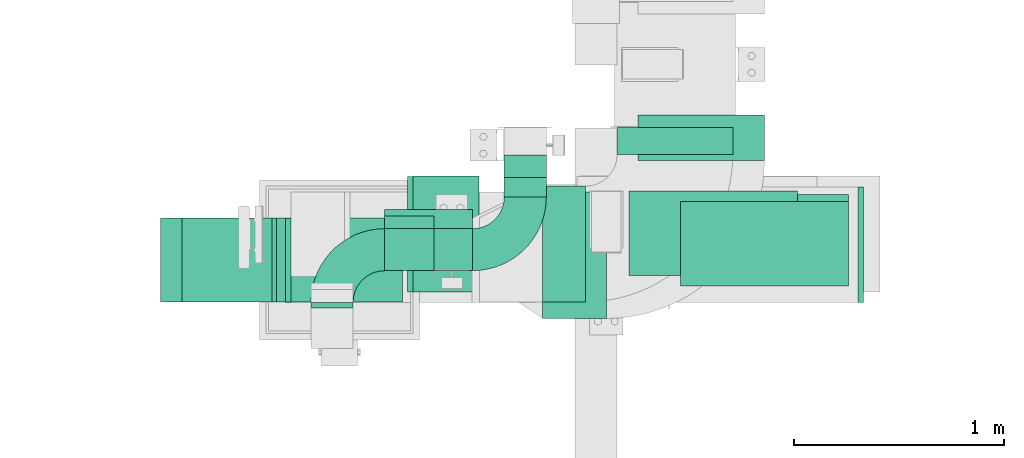
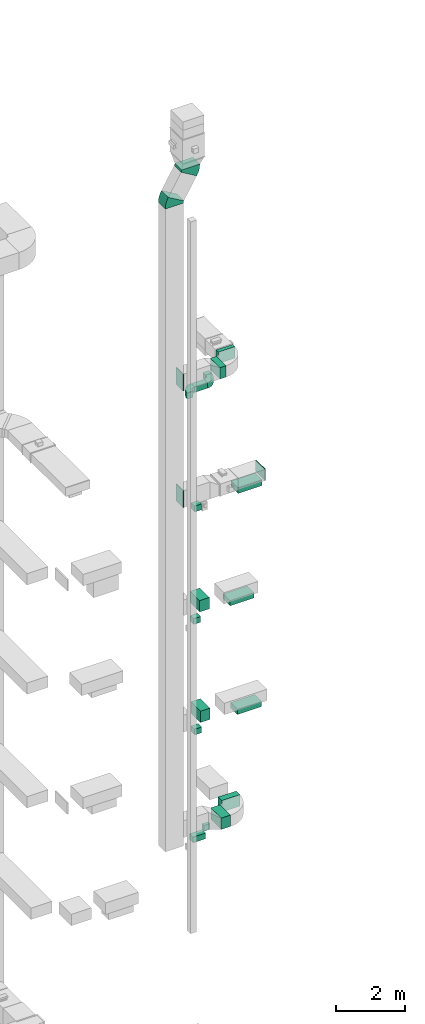
# One storey, part 10 of 25: 16 flow segments, 9 flow fittings.
"""IFC2X3 building model written with IfcOpenShell, lengths in millimetres."""

from ifc_helpers import new_model, entity, si_unit, converted_unit, derived_unit, direction, frame, frame_2d, origin, origin_2d_with_axis, place, context, subcontext, project, spatial, polyline, circle_curve, parameter, trimmed, segment, composite_curve, rectangle, outline, extrude, source, transform, mapped, material, type_object, type_shapes, element, save


model = new_model("IFC2X3")

# Units and contexts
model_context = context("Model", 3, precision=0.01, world=origin(), true_north=direction((6.12303176911189e-17, 1.0)))
body_context = subcontext(model_context, "Body", "Model", "MODEL_VIEW")
ifc_project = project(units=[si_unit("LENGTHUNIT", "METRE", prefix="MILLI"), si_unit("AREAUNIT", "SQUARE_METRE"), si_unit("VOLUMEUNIT", "CUBIC_METRE"), converted_unit("PLANEANGLEUNIT", "DEGREE", entity("IfcRatioMeasure", 0.0174532925199433), si_unit("PLANEANGLEUNIT", "RADIAN"), dimensions=[0, 0, 0, 0, 0, 0, 0]), si_unit("MASSUNIT", "GRAM", prefix="KILO"), derived_unit("MASSDENSITYUNIT", [(si_unit("MASSUNIT", "GRAM", prefix="KILO"), 1), (si_unit("LENGTHUNIT", "METRE"), -3)]), derived_unit("MOMENTOFINERTIAUNIT", [(si_unit("LENGTHUNIT", "METRE"), 4)]), si_unit("TIMEUNIT", "SECOND"), si_unit("FREQUENCYUNIT", "HERTZ"), si_unit("THERMODYNAMICTEMPERATUREUNIT", "DEGREE_CELSIUS"), derived_unit("THERMALTRANSMITTANCEUNIT", [(si_unit("MASSUNIT", "GRAM", prefix="KILO"), 1), (si_unit("THERMODYNAMICTEMPERATUREUNIT", "KELVIN"), -1), (si_unit("TIMEUNIT", "SECOND"), -3)]), derived_unit("VOLUMETRICFLOWRATEUNIT", [(si_unit("LENGTHUNIT", "METRE"), 3), (si_unit("TIMEUNIT", "SECOND"), -1)]), derived_unit("MASSFLOWRATEUNIT", [(si_unit("MASSUNIT", "GRAM", prefix="KILO"), 1), (si_unit("TIMEUNIT", "SECOND"), -1)]), derived_unit("ROTATIONALFREQUENCYUNIT", [(si_unit("TIMEUNIT", "SECOND"), -1)]), si_unit("ELECTRICCURRENTUNIT", "AMPERE"), si_unit("ELECTRICVOLTAGEUNIT", "VOLT"), si_unit("POWERUNIT", "WATT"), si_unit("FORCEUNIT", "NEWTON", prefix="KILO"), si_unit("ILLUMINANCEUNIT", "LUX"), si_unit("LUMINOUSFLUXUNIT", "LUMEN"), si_unit("LUMINOUSINTENSITYUNIT", "CANDELA"), derived_unit("USERDEFINED", [(si_unit("MASSUNIT", "GRAM", prefix="KILO"), -1), (si_unit("LENGTHUNIT", "METRE"), -2), (si_unit("TIMEUNIT", "SECOND"), 3), (si_unit("LUMINOUSFLUXUNIT", "LUMEN"), 1)]), derived_unit("LINEARVELOCITYUNIT", [(si_unit("LENGTHUNIT", "METRE"), 1), (si_unit("TIMEUNIT", "SECOND"), -1)]), si_unit("PRESSUREUNIT", "PASCAL"), derived_unit("USERDEFINED", [(si_unit("LENGTHUNIT", "METRE"), -2), (si_unit("MASSUNIT", "GRAM", prefix="KILO"), 1), (si_unit("TIMEUNIT", "SECOND"), -2)]), derived_unit("LINEARFORCEUNIT", [(si_unit("MASSUNIT", "GRAM", prefix="KILO"), 1), (si_unit("LENGTHUNIT", "METRE"), 1), (si_unit("TIMEUNIT", "SECOND"), -2), (si_unit("LENGTHUNIT", "METRE"), -1)]), derived_unit("PLANARFORCEUNIT", [(si_unit("MASSUNIT", "GRAM", prefix="KILO"), 1), (si_unit("LENGTHUNIT", "METRE"), 1), (si_unit("TIMEUNIT", "SECOND"), -2), (si_unit("LENGTHUNIT", "METRE"), -2)])], contexts=[model_context])

# Site, building, storey
site_placement = place(None, origin())
site = spatial("IfcSite", under=ifc_project, at=site_placement, CompositionType="ELEMENT")
building_placement = place(site_placement, origin())
building = spatial("IfcBuilding", under=site, at=building_placement, CompositionType="ELEMENT")
storey_placement = place(building_placement, origin())
storey = spatial("IfcBuildingStorey", under=building, at=storey_placement, CompositionType="ELEMENT", Elevation=0.0)

# Flow segments
duct_segment_type = type_object("IfcDuctSegmentType", PredefinedType="NOTDEFINED")
flow_segment_1_placement = place(storey_placement, frame((11246.02, 14394.08, 7200.0)))
element("IfcFlowSegment", 1, at=flow_segment_1_placement, inside=storey, type_object=duct_segment_type, context=body_context, shape_type="SweptSolid", body=[
    extrude(rectangle(XDim=304.195841947545, YDim=600.0, at=origin_2d_with_axis()), frame((152.1, 300.0, 0.0), z_axis=(0.0, 0.0, 1.0), x_axis=(-1.0, 0.0, 0.0)), (0.0, 0.0, 1.0), 400.0),
])
flow_segment_2_placement = place(storey_placement, frame((11900.13, 14584.08, 10900.0)))
element("IfcFlowSegment", 2, at=flow_segment_2_placement, inside=storey, type_object=duct_segment_type, context=body_context, shape_type="SweptSolid", body=[
    extrude(rectangle(XDim=400.0, YDim=800.0, at=origin_2d_with_axis()), frame((400.0, 200.0, 0.0), z_axis=(0.0, 0.0, 1.0), x_axis=(0.0, 1.0, 0.0)), (0.0, 0.0, 1.0), 180.000000000002),
])
flow_segment_3_placement = place(storey_placement, frame((11657.13, 14599.08, 14800.0)))
element("IfcFlowSegment", 3, at=flow_segment_3_placement, inside=storey, type_object=duct_segment_type, context=body_context, shape_type="SweptSolid", body=[
    extrude(rectangle(XDim=400.0, YDim=800.0, at=origin_2d_with_axis()), frame((400.0, 200.0, 0.0), z_axis=(0.0, 0.0, 1.0), x_axis=(0.0, 1.0, 0.0)), (0.0, 0.0, 1.0), 180.0),
])
flow_segment_4_placement = place(storey_placement, frame((11900.13, 14549.08, 18700.0)))
element("IfcFlowSegment", 4, at=flow_segment_4_placement, inside=storey, type_object=duct_segment_type, context=body_context, shape_type="SweptSolid", body=[
    extrude(rectangle(XDim=800.0, YDim=400.0, at=origin_2d_with_axis()), frame((400.0, 200.0, 0.0)), (0.0, 0.0, 1.0), 179.999999999998),
])
flow_segment_5_placement = place(storey_placement, frame((10494.72, 14713.05, 6800.0)))
element("IfcFlowSegment", 5, at=flow_segment_5_placement, inside=storey, type_object=duct_segment_type, context=body_context, shape_type="SweptSolid", body=[
    extrude(rectangle(XDim=418.531127100544, YDim=200.0, at=origin_2d_with_axis()), frame((209.27, 100.0, 0.0)), (0.0, 0.0, 1.0), 200.0),
])
flow_segment_6_placement = place(storey_placement, frame((10494.72, 14620.84, 10650.0)))
element("IfcFlowSegment", 6, at=flow_segment_6_placement, inside=storey, type_object=duct_segment_type, context=body_context, shape_type="SweptSolid", body=[
    extrude(rectangle(XDim=235.157017077479, YDim=200.0, at=origin_2d_with_axis()), frame((117.58, 100.0, 0.0), z_axis=(0.0, 0.0, 1.0), x_axis=(-1.0, 0.0, 0.0)), (0.0, 0.0, 1.0), 199.999999999998),
])
flow_segment_7_placement = place(storey_placement, frame((10494.72, 14680.84, 14500.0)))
element("IfcFlowSegment", 7, at=flow_segment_7_placement, inside=storey, type_object=duct_segment_type, context=body_context, shape_type="SweptSolid", body=[
    extrude(rectangle(XDim=235.157017077474, YDim=200.0, at=origin_2d_with_axis()), frame((117.58, 100.0, 0.0), z_axis=(0.0, 0.0, 1.0), x_axis=(-1.0, 0.0, 0.0)), (0.0, 0.0, 1.0), 199.999999999998),
])
flow_segment_8_placement = place(storey_placement, frame((10494.72, 14620.84, 18500.0)))
element("IfcFlowSegment", 8, at=flow_segment_8_placement, inside=storey, type_object=duct_segment_type, context=body_context, shape_type="SweptSolid", body=[
    extrude(rectangle(XDim=235.157017077468, YDim=200.0, at=origin_2d_with_axis()), frame((117.58, 100.0, 0.0), z_axis=(0.0, 0.0, 1.0), x_axis=(-1.0, 0.0, 0.0)), (0.0, 0.0, 1.0), 199.999999999998),
])
flow_segment_9_placement = place(storey_placement, frame((10494.72, 14620.84, 22700.0)))
element("IfcFlowSegment", 9, at=flow_segment_9_placement, inside=storey, type_object=duct_segment_type, context=body_context, shape_type="SweptSolid", body=[
    extrude(rectangle(XDim=418.531127100544, YDim=200.0, at=origin_2d_with_axis()), frame((209.27, 100.0, 0.0)), (0.0, 0.0, 1.0), 199.999999999998),
])
flow_segment_10_placement = place(storey_placement, frame((11063.25, 14970.84, 22700.0)))
element("IfcFlowSegment", 10, at=flow_segment_10_placement, inside=storey, type_object=duct_segment_type, context=body_context, shape_type="SweptSolid", body=[
    extrude(rectangle(XDim=161.475899875038, YDim=200.0, at=origin_2d_with_axis()), frame((100.0, 80.74, 0.0), z_axis=(0.0, 0.0, 1.0), x_axis=(0.0, -1.0, 0.0)), (0.0, 0.0, 1.0), 199.999999999998),
])
flow_segment_11_placement = place(storey_placement, frame((11063.25, 15063.05, 6800.0)))
element("IfcFlowSegment", 11, at=flow_segment_11_placement, inside=storey, type_object=duct_segment_type, context=body_context, shape_type="SweptSolid", body=[
    extrude(rectangle(XDim=107.332237883446, YDim=200.0, at=origin_2d_with_axis()), frame((100.0, 53.67, 0.0), z_axis=(0.0, 0.0, 1.0), x_axis=(0.0, 1.0, 0.0)), (0.0, 0.0, 1.0), 200.0),
])
flow_segment_12_placement = place(storey_placement, frame((10629.73, 14520.08, 11100.0)))
element("IfcFlowSegment", 12, at=flow_segment_12_placement, inside=storey, type_object=duct_segment_type, context=body_context, shape_type="SweptSolid", body=[
    extrude(rectangle(XDim=313.893972744042, YDim=550.000000000001, at=origin_2d_with_axis()), frame((156.95, 275.0, 0.0), z_axis=(0.0, 0.0, 1.0), x_axis=(-1.0, 0.0, 0.0)), (0.0, 0.0, 1.0), 400.0),
])
flow_segment_13_placement = place(storey_placement, frame((10603.49, 14519.08, 15000.0)))
element("IfcFlowSegment", 13, at=flow_segment_13_placement, inside=storey, type_object=duct_segment_type, context=body_context, shape_type="SweptSolid", body=[
    extrude(rectangle(XDim=325.140823658918, YDim=550.000000000001, at=origin_2d_with_axis()), frame((162.57, 275.0, 0.0), z_axis=(0.0, 0.0, 1.0), x_axis=(-1.0, 0.0, 0.0)), (0.0, 0.0, 1.0), 400.0),
])
flow_segment_14_placement = place(storey_placement, frame((11599.64, 15172.56, 23000.0)))
element("IfcFlowSegment", 14, at=flow_segment_14_placement, inside=storey, type_object=duct_segment_type, context=body_context, shape_type="SweptSolid", body=[
    extrude(rectangle(XDim=128.921794173047, YDim=550.000000000001, at=origin_2d_with_axis()), frame((275.0, 64.46, 0.0), z_axis=(0.0, 0.0, 1.0), x_axis=(0.0, -1.0, 0.0)), (0.0, 0.0, 1.0), 399.999999999996),
])
flow_segment_15_placement = place(storey_placement, frame((11245.77, 14472.56, 23000.0)))
element("IfcFlowSegment", 15, at=flow_segment_15_placement, inside=storey, type_object=duct_segment_type, context=body_context, shape_type="SweptSolid", body=[
    extrude(rectangle(XDim=203.872764732928, YDim=550.000000000001, at=origin_2d_with_axis()), frame((101.94, 275.0, 0.0)), (0.0, 0.0, 1.0), 399.999999999996),
])
flow_segment_16_placement = place(storey_placement, frame((11700.22, 15144.08, 7200.0)))
element("IfcFlowSegment", 16, at=flow_segment_16_placement, inside=storey, type_object=duct_segment_type, context=body_context, shape_type="SweptSolid", body=[
    extrude(rectangle(XDim=216.297032725026, YDim=600.0, at=origin_2d_with_axis()), frame((300.0, 108.15, 0.0), z_axis=(0.0, 0.0, 1.0), x_axis=(0.0, -1.0, 0.0)), (0.0, 0.0, 1.0), 400.0),
])

# Flow fittings
ifc_material = material()
duct_fitting_type_1 = type_object("IfcDuctFittingType", PredefinedType="NOTDEFINED", material=ifc_material)
shared_shape_1 = source(origin(), body_context, "Body", "SweptSolid", [
    extrude(rectangle(XDim=26.0960000000012, YDim=800.0, at=origin_2d_with_axis()), frame((6.95, 0.0, -200.0)), (0.0, 0.0, 1.0), 400.0),
])
type_shapes(duct_fitting_type_1, [shared_shape_1])
flow_fitting_1_placement = place(storey_placement, frame((12300.13, 14749.08, 18900.0), z_axis=(0.0, 1.0, 0.0), x_axis=(0.0, 0.0, -1.0)))
element("IfcFlowFitting", 17, at=flow_fitting_1_placement, inside=storey, type_object=duct_fitting_type_1, material=ifc_material, context=body_context, shape_type="MappedRepresentation", body=[
    mapped(shared_shape_1, transform((0.0, 0.0, 0.0), scale=1.0)),
])
duct_fitting_type_2 = type_object("IfcDuctFittingType", PredefinedType="NOTDEFINED", material=ifc_material)
shared_shape_2 = source(origin(), body_context, "Body", "SweptSolid", [
    extrude(rectangle(XDim=24.9999999999999, YDim=550.0, at=origin_2d_with_axis()), frame((12.5, 0.0, -200.0)), (0.0, 0.0, 1.0), 400.0),
])
type_shapes(duct_fitting_type_2, [shared_shape_2])
flow_fitting_2_placement = place(storey_placement, frame((12745.77, 14744.56, 19100.0)))
element("IfcFlowFitting", 18, at=flow_fitting_2_placement, inside=storey, type_object=duct_fitting_type_2, material=ifc_material, context=body_context, shape_type="MappedRepresentation", body=[
    mapped(shared_shape_2, transform((0.0, 0.0, 0.0), scale=1.0)),
])
duct_fitting_type_3 = type_object("IfcDuctFittingType", PredefinedType="NOTDEFINED", material=ifc_material)
shared_shape_3 = source(origin(), body_context, "Body", "SweptSolid", [
    extrude(rectangle(XDim=600.0, YDim=26.096, at=origin_2d_with_axis()), frame((6.95, 0.0, -200.0), z_axis=(0.0, 0.0, 1.0), x_axis=(0.0, -1.0, 0.0)), (0.0, 0.0, 1.0), 400.0),
])
type_shapes(duct_fitting_type_3, [shared_shape_3])
for number, where, z_axis, x_axis in (
    (19, (10029.73, 14669.56, 19200.0), (0.0, -1.0, 0.0), (1.0, 0.0, 0.0)),
    (20, (10029.73, 14672.56, 23300.0), (0.0, -1.0, 0.0), (1.0, 0.0, 0.0)),
):
    element("IfcFlowFitting", number, at=place(storey_placement, frame(where, z_axis=z_axis, x_axis=x_axis)), inside=storey, type_object=duct_fitting_type_3, material=ifc_material, context=body_context, shape_type="MappedRepresentation", body=[
        mapped(shared_shape_3, transform((0.0, 0.0, 0.0), scale=1.0)),
    ])
duct_fitting_type_4 = type_object("IfcDuctFittingType", PredefinedType="NOTDEFINED", material=ifc_material)
shared_shape_4 = source(origin(), body_context, "Body", "SweptSolid", [
    extrude(rectangle(XDim=26.0960000000003, YDim=200.0, at=origin_2d_with_axis()), frame((6.95, 0.0, -100.0)), (0.0, 0.0, 1.0), 200.0),
])
type_shapes(duct_fitting_type_4, [shared_shape_4])
flow_fitting_3_placement = place(storey_placement, frame((10244.72, 14450.84, 22800.0), z_axis=(1.0, 0.0, 0.0), x_axis=(0.0, 1.0, 0.0)))
element("IfcFlowFitting", 21, at=flow_fitting_3_placement, inside=storey, type_object=duct_fitting_type_4, material=ifc_material, context=body_context, shape_type="MappedRepresentation", body=[
    mapped(shared_shape_4, transform((0.0, 0.0, 0.0), scale=1.0)),
])
duct_fitting_type_5 = type_object("IfcDuctFittingType", PredefinedType="NOTDEFINED", material=ifc_material)
shared_shape_5 = source(origin(), body_context, "Body", "SweptSolid", [
    extrude(outline(composite_curve([segment(polyline([(-225.0, -125.0), (-25.0, -125.0)]), True, "CONTINUOUS"), segment(trimmed(circle_curve(frame_2d((125.0, -125.0), x_axis=(0.0, 1.0)), 150.0), [parameter(0.0)], [parameter(90.0000000000001)], True, "PARAMETER"), False, "CONTINUOUS"), segment(polyline([(125.0, 25.0), (125.0, 225.0)]), True, "CONTINUOUS"), segment(trimmed(circle_curve(frame_2d((125.0, -125.0), x_axis=(0.0, 1.0)), 350.0), [parameter(0.0)], [parameter(90.0000000000001)], True, "PARAMETER"), True, "CONTINUOUS")], self_intersect=False)), frame((-125.0, 125.0, -100.0), z_axis=(0.0, 0.0, 1.0), x_axis=(-1.0, 0.0, 0.0)), (0.0, 0.0, 1.0), 200.0),
])
type_shapes(duct_fitting_type_5, [shared_shape_5])
flow_fitting_4_placement = place(storey_placement, frame((10244.72, 14720.84, 22800.0), z_axis=(0.0, 0.0, 1.0), x_axis=(-1.0, 0.0, 0.0)))
element("IfcFlowFitting", 22, at=flow_fitting_4_placement, inside=storey, type_object=duct_fitting_type_5, material=ifc_material, context=body_context, shape_type="MappedRepresentation", body=[
    mapped(shared_shape_5, transform((0.0, 0.0, 0.0), scale=1.0)),
])
flow_fitting_5_placement = place(storey_placement, frame((11163.25, 14720.84, 22800.0)))
element("IfcFlowFitting", 23, at=flow_fitting_5_placement, inside=storey, type_object=duct_fitting_type_5, material=ifc_material, context=body_context, shape_type="MappedRepresentation", body=[
    mapped(shared_shape_5, transform((0.0, 0.0, 0.0), scale=1.0)),
])
duct_fitting_type_6 = type_object("IfcDuctFittingType", PredefinedType="NOTDEFINED", material=ifc_material)
shared_shape_6 = source(origin(), body_context, "Body", "SweptSolid", [
    extrude(outline(composite_curve([segment(polyline([(-330.8, -113.63), (269.2, -113.63)]), True, "CONTINUOUS"), segment(trimmed(circle_curve(frame_2d((419.2, -113.63), x_axis=(-0.863112091262842, 0.505012393824039)), 150.0), [parameter(0.0)], [parameter(30.3321750963018)], True, "PARAMETER"), False, "CONTINUOUS"), segment(polyline([(289.73, -37.88), (-228.13, 265.13)]), True, "CONTINUOUS"), segment(trimmed(circle_curve(frame_2d((419.2, -113.63), x_axis=(-0.863112091262842, 0.505012393824039)), 750.0), [parameter(0.0)], [parameter(30.3321750963018)], True, "PARAMETER"), True, "CONTINUOUS")], self_intersect=False)), frame((-8.35, 30.8, -200.0), z_axis=(0.0, 0.0, 1.0), x_axis=(-0.505012393824038, 0.863112091262841, 0.0)), (0.0, 0.0, 1.0), 400.0),
])
type_shapes(duct_fitting_type_6, [shared_shape_6])
for number, where, z_axis, x_axis in (
    (24, (10279.73, 14672.56, 30680.0), (0.0, 1.0, 0.0), (0.0, 0.0, -1.0)),
    (25, (9729.73, 14672.56, 29740.0), (0.0, 1.0, 0.0), (0.0, 0.0, 1.0)),
):
    element("IfcFlowFitting", number, at=place(storey_placement, frame(where, z_axis=z_axis, x_axis=x_axis)), inside=storey, type_object=duct_fitting_type_6, material=ifc_material, context=body_context, shape_type="MappedRepresentation", body=[
        mapped(shared_shape_6, transform((0.0, 0.0, 0.0), scale=1.0)),
    ])

save(model, "model.ifc")
